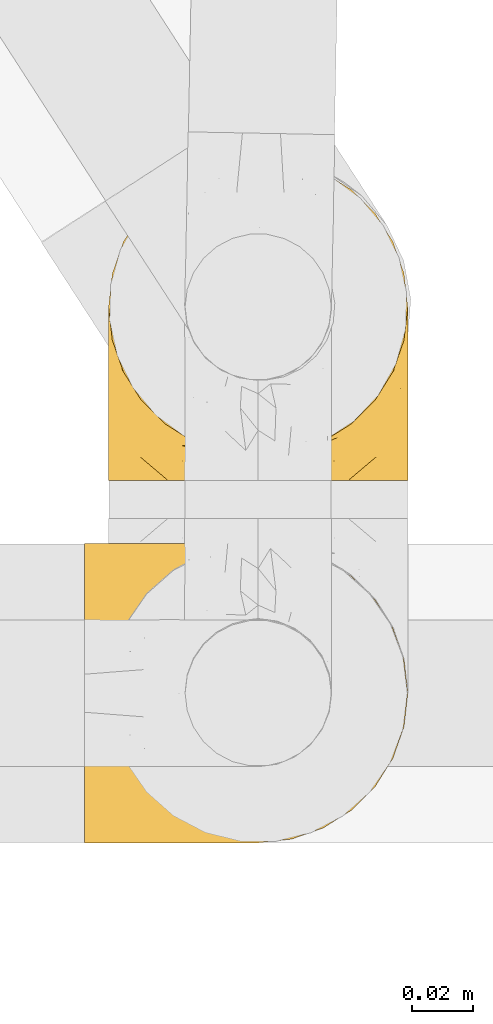
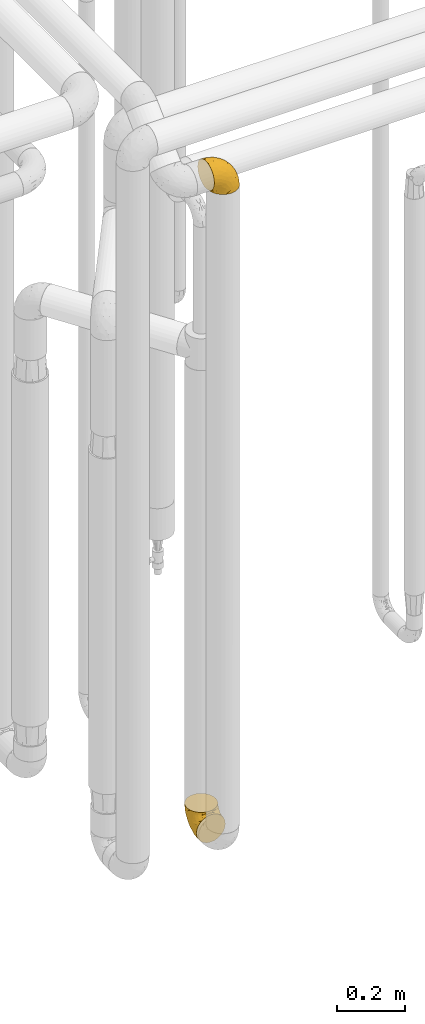
# One storey, part 387 of 827: 2 coverings.
"""IFC2X3 building model written with IfcOpenShell, lengths in millimetres."""

from ifc_helpers import new_model, entity, si_unit, converted_unit, derived_unit, direction, frame, origin, place, context, subcontext, project, spatial, faceted_brep, element, save


model = new_model("IFC2X3")

# Units and contexts
model_context = context("Model", 3, precision=0.01, world=origin(), true_north=direction((6.12303176911189e-17, 1.0)))
body_context = subcontext(model_context, "Body", "Model", "MODEL_VIEW")
ifc_project = project(units=[si_unit("LENGTHUNIT", "METRE", prefix="MILLI"), si_unit("AREAUNIT", "SQUARE_METRE"), si_unit("VOLUMEUNIT", "CUBIC_METRE"), converted_unit("PLANEANGLEUNIT", "DEGREE", entity("IfcRatioMeasure", 0.0174532925199433), si_unit("PLANEANGLEUNIT", "RADIAN"), dimensions=[0, 0, 0, 0, 0, 0, 0]), si_unit("MASSUNIT", "GRAM", prefix="KILO"), derived_unit("MASSDENSITYUNIT", [(si_unit("MASSUNIT", "GRAM", prefix="KILO"), 1), (si_unit("LENGTHUNIT", "METRE"), -3)]), derived_unit("MOMENTOFINERTIAUNIT", [(si_unit("LENGTHUNIT", "METRE"), 4)]), si_unit("TIMEUNIT", "SECOND"), si_unit("FREQUENCYUNIT", "HERTZ"), si_unit("THERMODYNAMICTEMPERATUREUNIT", "DEGREE_CELSIUS"), derived_unit("THERMALTRANSMITTANCEUNIT", [(si_unit("MASSUNIT", "GRAM", prefix="KILO"), 1), (si_unit("THERMODYNAMICTEMPERATUREUNIT", "KELVIN"), -1), (si_unit("TIMEUNIT", "SECOND"), -3)]), derived_unit("VOLUMETRICFLOWRATEUNIT", [(si_unit("LENGTHUNIT", "METRE"), 3), (si_unit("TIMEUNIT", "SECOND"), -1)]), derived_unit("MASSFLOWRATEUNIT", [(si_unit("MASSUNIT", "GRAM", prefix="KILO"), 1), (si_unit("TIMEUNIT", "SECOND"), -1)]), derived_unit("ROTATIONALFREQUENCYUNIT", [(si_unit("TIMEUNIT", "SECOND"), -1)]), si_unit("ELECTRICCURRENTUNIT", "AMPERE"), si_unit("ELECTRICVOLTAGEUNIT", "VOLT"), si_unit("POWERUNIT", "WATT"), si_unit("FORCEUNIT", "NEWTON", prefix="KILO"), si_unit("ILLUMINANCEUNIT", "LUX"), si_unit("LUMINOUSFLUXUNIT", "LUMEN"), si_unit("LUMINOUSINTENSITYUNIT", "CANDELA"), derived_unit("USERDEFINED", [(si_unit("MASSUNIT", "GRAM", prefix="KILO"), -1), (si_unit("LENGTHUNIT", "METRE"), -2), (si_unit("TIMEUNIT", "SECOND"), 3), (si_unit("LUMINOUSFLUXUNIT", "LUMEN"), 1)]), derived_unit("LINEARVELOCITYUNIT", [(si_unit("LENGTHUNIT", "METRE"), 1), (si_unit("TIMEUNIT", "SECOND"), -1)]), si_unit("PRESSUREUNIT", "PASCAL"), derived_unit("USERDEFINED", [(si_unit("LENGTHUNIT", "METRE"), -2), (si_unit("MASSUNIT", "GRAM", prefix="KILO"), 1), (si_unit("TIMEUNIT", "SECOND"), -2)]), derived_unit("LINEARFORCEUNIT", [(si_unit("MASSUNIT", "GRAM", prefix="KILO"), 1), (si_unit("LENGTHUNIT", "METRE"), 1), (si_unit("TIMEUNIT", "SECOND"), -2), (si_unit("LENGTHUNIT", "METRE"), -1)]), derived_unit("PLANARFORCEUNIT", [(si_unit("MASSUNIT", "GRAM", prefix="KILO"), 1), (si_unit("LENGTHUNIT", "METRE"), 1), (si_unit("TIMEUNIT", "SECOND"), -2), (si_unit("LENGTHUNIT", "METRE"), -2)])], contexts=[model_context])

# Site, building, storey
site_placement = place(None, origin())
site = spatial("IfcSite", under=ifc_project, at=site_placement, CompositionType="ELEMENT")
building_placement = place(site_placement, origin())
building = spatial("IfcBuilding", under=site, at=building_placement, CompositionType="ELEMENT")
storey_placement = place(building_placement, frame((0.0, 0.0, 28200.0)))
storey = spatial("IfcBuildingStorey", under=building, at=storey_placement, Name="08", CompositionType="ELEMENT", Elevation=28200.0)

# Coverings
covering_1_placement = place(storey_placement, frame((46939.93, 13586.09, 2751.18)))
element("IfcCovering", 1, at=covering_1_placement, inside=storey, Name=":ADSK_", ObjectType=":ADSK_", PredefinedType="INSULATION", context=body_context, shape_type="Brep", body=[
    faceted_brep([(58.6, 99.9, 1.61), (69.54, 98.67, 1.61), (79.93, 95.03, 1.61), (89.25, 89.18, 1.61), (97.03, 81.39, 1.61), (102.88, 72.07, 1.61), (106.51, 61.69, 1.61), (107.75, 50.75, 1.6), (106.51, 39.81, 1.6), (102.87, 29.42, 1.6), (97.02, 20.1, 1.6), (89.23, 12.32, 1.6), (79.91, 6.47, 1.6), (69.53, 2.84, 1.6), (58.6, 1.6, 1.6), (52.89, 2.25, 1.6), (47.65, 2.84, 1.6), (42.46, 4.66, 1.6), (37.26, 6.48, 1.6), (27.94, 12.33, 1.6), (20.16, 20.12, 1.6), (14.31, 29.44, 1.6), (10.68, 39.82, 1.6), (9.45, 50.75, 1.6), (10.68, 61.7, 1.61), (14.32, 72.09, 1.61), (20.17, 81.41, 1.61), (27.96, 89.19, 1.61), (37.28, 95.04, 1.61), (42.47, 96.86, 1.61), (47.66, 98.67, 1.61), (52.89, 99.26, 1.61), (55.75, 99.58, 1.61), (1.6, 38.03, 11.13), (1.6, 26.18, 16.03), (1.6, 21.09, 19.94), (1.6, 16.0, 23.84), (1.6, 12.09, 28.93), (1.6, 8.18, 34.02), (1.6, 5.73, 39.95), (1.6, 3.27, 45.87), (1.6, 2.35, 52.86), (1.6, 1.97, 55.73), (1.6, 1.6, 58.6), (1.6, 3.27, 71.32), (1.6, 8.18, 83.17), (1.6, 15.99, 93.35), (1.6, 26.16, 101.16), (1.6, 38.02, 106.08), (1.6, 50.74, 107.75), (1.6, 63.46, 106.08), (1.6, 75.31, 101.17), (1.6, 85.49, 93.36), (1.6, 93.31, 83.19), (1.6, 98.22, 71.33), (1.6, 99.9, 58.61), (1.6, 99.14, 52.88), (1.6, 98.22, 45.89), (1.6, 95.77, 39.96), (1.6, 93.31, 34.04), (1.6, 89.41, 28.94), (1.6, 85.51, 23.85), (1.6, 80.42, 19.95), (1.6, 75.33, 16.04), (1.6, 63.47, 11.13), (1.6, 50.75, 9.45), (69.96, 59.3, 81.82), (59.59, 73.07, 84.04), (51.96, 63.71, 93.06), (34.4, 50.74, 102.56), (23.37, 58.63, 104.84), (13.68, 50.74, 105.84), (41.52, 76.73, 91.89), (26.26, 67.68, 101.75), (20.18, 78.92, 97.09), (72.33, 94.31, 38.46), (65.88, 98.77, 22.19), (57.55, 98.4, 42.06), (23.76, 94.56, 77.7), (46.5, 89.91, 75.77), (46.57, 96.32, 62.12), (21.17, 98.78, 66.09), (23.41, 99.9, 54.27), (17.92, 99.9, 55.36), (12.43, 99.9, 56.46), (9.72, 99.9, 56.99), (7.01, 99.9, 57.53), (26.77, 87.31, 87.85), (76.59, 95.61, 19.42), (95.55, 60.43, 48.9), (102.57, 65.24, 26.35), (92.89, 72.87, 44.56), (54.26, 99.9, 23.42), (51.17, 99.9, 28.05), (48.08, 99.9, 32.67), (44.99, 99.9, 37.29), (41.9, 99.9, 41.92), (85.16, 90.65, 20.62), (85.97, 63.14, 63.37), (59.58, 91.89, 62.22), (99.5, 75.26, 19.95), (105.83, 50.75, 13.69), (53.59, 82.18, 80.86), (67.0, 85.08, 66.54), (71.56, 76.93, 71.07), (87.47, 50.74, 64.0), (75.73, 50.74, 75.74), (92.24, 83.02, 26.78), (58.06, 99.9, 4.32), (57.52, 99.9, 7.03), (56.44, 99.9, 12.45), (55.35, 99.9, 17.94), (81.33, 87.14, 43.44), (80.35, 80.85, 56.24), (39.44, 99.17, 54.99), (102.55, 50.75, 34.41), (37.28, 99.9, 45.01), (32.65, 99.9, 48.09), (28.03, 99.9, 51.18), (63.99, 50.74, 87.48), (74.55, 67.6, 74.56), (83.62, 72.25, 60.87), (95.01, 50.75, 49.2), (49.19, 50.74, 95.02), (46.96, 98.7, 10.28), (8.77, 99.02, 48.8), (18.28, 98.8, 45.18), (11.68, 98.29, 45.0), (11.79, 68.52, 6.18), (15.69, 76.83, 7.66), (42.49, 98.54, 21.61), (47.41, 99.3, 19.98), (7.94, 83.58, 21.01), (9.27, 89.47, 27.22), (7.98, 75.77, 14.84), (13.4, 84.86, 19.72), (13.04, 75.89, 10.94), (7.36, 64.78, 9.64), (23.46, 90.84, 19.99), (30.46, 94.63, 21.14), (26.54, 90.38, 14.15), (6.76, 91.19, 30.21), (26.46, 88.65, 8.13), (20.77, 84.12, 9.94), (20.68, 91.75, 24.63), (40.26, 96.87, 11.88), (7.15, 50.75, 7.15), (9.28, 58.98, 5.33), (38.78, 98.38, 26.7), (18.27, 83.92, 13.93), (31.78, 97.53, 30.69), (12.75, 95.55, 36.67), (22.96, 98.76, 42.9), (17.55, 95.26, 34.06), (27.63, 98.04, 36.61), (15.23, 90.66, 26.42), (33.25, 93.52, 10.09), (32.43, 94.17, 15.85), (27.9, 99.1, 42.01), (7.97, 25.74, 14.83), (15.22, 10.85, 26.41), (7.93, 17.92, 21.01), (13.38, 16.65, 19.71), (13.12, 30.45, 5.73), (42.49, 2.96, 21.6), (47.4, 2.2, 19.96), (51.17, 1.6, 28.03), (40.24, 4.64, 11.87), (20.76, 17.4, 9.93), (4.31, 1.6, 58.06), (12.43, 1.6, 56.44), (7.01, 1.6, 57.52), (26.44, 12.87, 8.13), (26.52, 11.13, 14.15), (11.68, 3.2, 44.99), (12.75, 5.95, 36.66), (9.27, 12.02, 27.21), (17.55, 6.24, 34.04), (6.76, 10.31, 30.2), (33.21, 8.01, 10.06), (32.41, 7.34, 15.83), (8.77, 2.48, 48.79), (22.96, 2.73, 42.89), (18.48, 2.64, 45.38), (56.44, 1.6, 12.43), (46.95, 2.81, 10.28), (7.36, 36.72, 9.65), (17.92, 1.6, 55.35), (23.41, 1.6, 54.26), (9.85, 38.59, 6.05), (57.52, 1.6, 7.01), (56.98, 1.6, 9.72), (48.08, 1.6, 32.65), (38.78, 3.12, 26.68), (18.25, 17.59, 13.92), (44.99, 1.6, 37.28), (31.74, 3.99, 30.66), (30.45, 6.87, 21.14), (27.63, 3.46, 36.59), (20.65, 9.77, 24.6), (55.35, 1.6, 17.92), (54.26, 1.6, 23.41), (13.03, 25.63, 10.93), (23.44, 10.67, 19.98), (27.9, 2.39, 41.99), (32.65, 1.6, 48.08), (28.03, 1.6, 51.17), (37.28, 1.6, 44.99), (41.9, 1.6, 41.9), (39.74, 2.4, 55.26), (23.37, 42.84, 104.84), (26.77, 14.17, 87.84), (46.18, 11.55, 75.91), (53.54, 19.27, 80.85), (41.53, 24.75, 91.88), (59.61, 28.37, 83.98), (76.79, 5.95, 19.17), (66.11, 2.8, 22.37), (21.17, 2.7, 66.08), (51.96, 37.77, 93.06), (26.26, 33.8, 101.75), (20.18, 22.56, 97.08), (23.76, 6.92, 77.69), (92.88, 28.61, 44.55), (102.57, 36.24, 26.35), (95.54, 41.05, 48.91), (71.63, 24.55, 70.99), (74.55, 33.88, 74.55), (72.51, 7.12, 37.8), (69.96, 42.18, 81.82), (92.23, 18.47, 26.77), (85.15, 10.84, 20.6), (80.45, 20.69, 56.15), (83.65, 29.27, 60.86), (57.57, 3.1, 42.06), (63.68, 9.18, 57.03), (85.95, 38.38, 63.4), (99.49, 26.23, 19.95), (81.23, 14.35, 43.59), (47.07, 5.46, 62.61), (66.99, 16.39, 66.52)], [[[0, 1, 2, 3, 4, 5, 6, 7, 8, 9, 10, 11, 12, 13, 14, 15, 16, 17, 18, 19, 20, 21, 22, 23, 24, 25, 26, 27, 28, 29, 30, 31, 32]], [[33, 34, 35, 36, 37, 38, 39, 40, 41, 42, 43, 44, 45, 46, 47, 48, 49, 50, 51, 52, 53, 54, 55, 56, 57, 58, 59, 60, 61, 62, 63, 64, 65]], [[66, 67, 68]], [[69, 70, 71]], [[68, 72, 73]], [[73, 72, 74]], [[75, 76, 77]], [[78, 79, 80]], [[51, 50, 73]], [[81, 82, 83, 84, 85, 86, 55]], [[52, 87, 53]], [[74, 52, 51]], [[2, 1, 88]], [[89, 90, 91]], [[77, 92, 93, 94, 95, 96]], [[55, 54, 81]], [[78, 53, 87]], [[5, 90, 6]], [[88, 76, 75]], [[97, 3, 2]], [[89, 91, 98]], [[99, 80, 79]], [[90, 5, 100]], [[74, 87, 52]], [[100, 5, 4]], [[90, 101, 6]], [[79, 102, 103]], [[102, 67, 104]], [[105, 98, 106]], [[107, 4, 3]], [[76, 0, 108, 109, 110, 111, 92]], [[107, 112, 113]], [[114, 77, 96]], [[89, 115, 90]], [[114, 96, 116, 117, 118, 82]], [[75, 97, 88]], [[119, 66, 68]], [[50, 71, 70]], [[100, 91, 90]], [[99, 77, 80]], [[102, 104, 103]], [[97, 107, 3]], [[80, 81, 78]], [[107, 97, 112]], [[68, 73, 70]], [[66, 98, 120]], [[78, 81, 54]], [[114, 81, 80]], [[53, 78, 54]], [[78, 87, 79]], [[102, 87, 72]], [[79, 103, 99]], [[4, 107, 100]], [[91, 100, 107]], [[88, 97, 2]], [[112, 97, 75]], [[99, 112, 75]], [[103, 104, 113]], [[91, 121, 98]], [[89, 105, 122, 115]], [[101, 90, 115]], [[101, 7, 6]], [[88, 1, 76]], [[0, 76, 1]], [[92, 77, 76]], [[73, 74, 51]], [[87, 74, 72]], [[81, 114, 82]], [[77, 114, 80]], [[87, 102, 79]], [[67, 102, 72]], [[68, 67, 72]], [[67, 120, 104]], [[120, 121, 104]], [[104, 121, 113]], [[121, 120, 98]], [[91, 107, 113]], [[91, 113, 121]], [[103, 113, 112]], [[106, 98, 66]], [[105, 89, 98]], [[106, 66, 119]], [[67, 66, 120]], [[68, 69, 123, 119]], [[50, 49, 71]], [[50, 70, 73]], [[112, 99, 103]], [[77, 99, 75]], [[69, 68, 70]], [[29, 124, 110]], [[84, 83, 125]], [[126, 82, 118]], [[59, 58, 127]], [[25, 128, 129]], [[130, 93, 131]], [[132, 62, 133]], [[134, 135, 136]], [[137, 65, 64]], [[64, 134, 137]], [[138, 139, 140]], [[111, 110, 124, 92]], [[134, 136, 137]], [[134, 64, 63]], [[133, 61, 141]], [[125, 58, 57]], [[142, 143, 140]], [[142, 26, 143]], [[127, 83, 82]], [[28, 124, 29]], [[32, 31, 30, 110, 109, 108, 0]], [[30, 29, 110]], [[135, 144, 138]], [[28, 145, 124]], [[57, 56, 55, 86, 85, 84]], [[146, 147, 23]], [[24, 23, 147]], [[25, 143, 26]], [[95, 94, 148]], [[24, 128, 25]], [[149, 138, 143]], [[124, 145, 131]], [[127, 58, 125]], [[150, 148, 139]], [[127, 126, 151]], [[151, 59, 127]], [[152, 151, 126]], [[153, 154, 155]], [[153, 133, 141]], [[145, 28, 27]], [[142, 156, 27]], [[157, 148, 130]], [[61, 133, 62]], [[134, 132, 135]], [[147, 128, 24]], [[65, 137, 146]], [[146, 137, 147]], [[128, 137, 136]], [[137, 128, 147]], [[128, 136, 129]], [[149, 129, 136]], [[25, 129, 143]], [[158, 152, 117]], [[152, 118, 117]], [[153, 151, 152]], [[158, 116, 154]], [[144, 150, 138]], [[153, 152, 158]], [[133, 153, 155]], [[133, 155, 132]], [[141, 61, 60]], [[135, 132, 155]], [[134, 63, 132]], [[144, 135, 155]], [[135, 138, 149]], [[155, 154, 144]], [[150, 154, 96]], [[154, 150, 144]], [[148, 94, 130]], [[82, 126, 127]], [[118, 152, 126]], [[150, 96, 95]], [[139, 148, 157]], [[150, 95, 148]], [[93, 92, 131]], [[130, 145, 156]], [[130, 94, 93]], [[84, 125, 57]], [[127, 125, 83]], [[140, 139, 157]], [[150, 139, 138]], [[140, 157, 142]], [[138, 140, 143]], [[156, 142, 157]], [[27, 26, 142]], [[130, 156, 157]], [[145, 27, 156]], [[132, 63, 62]], [[124, 131, 92]], [[130, 131, 145]], [[129, 149, 143]], [[135, 149, 136]], [[60, 151, 141]], [[59, 151, 60]], [[141, 151, 153]], [[116, 96, 154]], [[153, 158, 154]], [[158, 117, 116]], [[34, 33, 159]], [[160, 161, 162]], [[22, 21, 163]], [[164, 165, 166]], [[19, 18, 167]], [[168, 21, 20]], [[169, 43, 42, 41, 40, 170, 171]], [[172, 173, 168]], [[174, 38, 175]], [[176, 177, 178]], [[179, 164, 180]], [[40, 181, 170]], [[182, 183, 175]], [[17, 184, 185]], [[65, 146, 186]], [[187, 174, 188]], [[23, 22, 189]], [[174, 39, 38]], [[15, 14, 190, 191, 184, 16]], [[181, 40, 39]], [[192, 193, 164]], [[194, 163, 168]], [[33, 186, 159]], [[180, 173, 172]], [[195, 196, 193]], [[18, 185, 167]], [[173, 180, 197]], [[198, 199, 196]], [[200, 201, 185, 184]], [[184, 17, 16]], [[18, 17, 185]], [[202, 159, 186]], [[194, 168, 203]], [[189, 163, 202]], [[204, 205, 182]], [[187, 181, 174]], [[160, 177, 176]], [[206, 183, 182]], [[206, 182, 205]], [[201, 165, 185]], [[165, 164, 167]], [[172, 179, 180]], [[202, 194, 162]], [[176, 161, 160]], [[65, 186, 33]], [[163, 189, 22]], [[175, 177, 182]], [[174, 183, 188]], [[177, 198, 204]], [[199, 160, 162]], [[198, 207, 204]], [[175, 38, 37]], [[198, 177, 160]], [[178, 177, 175]], [[176, 35, 161]], [[34, 159, 161]], [[162, 161, 159]], [[202, 162, 159]], [[199, 162, 203]], [[196, 199, 203]], [[198, 160, 199]], [[193, 197, 180]], [[208, 198, 196]], [[188, 183, 206]], [[175, 183, 174]], [[193, 192, 195]], [[195, 208, 196]], [[197, 196, 203]], [[180, 164, 193]], [[168, 163, 21]], [[166, 165, 201]], [[166, 192, 164]], [[189, 202, 186]], [[186, 146, 189]], [[23, 189, 146]], [[174, 181, 39]], [[170, 181, 187]], [[196, 197, 193]], [[173, 203, 168]], [[203, 173, 197]], [[172, 168, 20]], [[20, 19, 172]], [[179, 172, 19]], [[19, 167, 179]], [[164, 179, 167]], [[35, 176, 36]], [[35, 34, 161]], [[185, 165, 167]], [[162, 194, 203]], [[163, 194, 202]], [[176, 178, 36]], [[37, 36, 178]], [[175, 37, 178]], [[177, 204, 182]], [[207, 198, 208]], [[207, 205, 204]], [[209, 188, 206, 205, 207, 208]], [[48, 210, 71]], [[211, 212, 213]], [[214, 213, 215]], [[216, 217, 13]], [[218, 43, 169, 171, 170, 187, 188]], [[219, 220, 214]], [[47, 46, 221]], [[210, 48, 220]], [[211, 222, 212]], [[222, 45, 44]], [[221, 220, 47]], [[47, 220, 48]], [[221, 211, 214]], [[223, 224, 225]], [[211, 46, 45]], [[226, 227, 215]], [[43, 218, 44]], [[217, 216, 228]], [[215, 229, 219]], [[14, 13, 217]], [[224, 9, 8]], [[10, 230, 11]], [[11, 231, 12]], [[232, 223, 233]], [[234, 208, 195, 192, 166, 201]], [[235, 234, 228]], [[222, 44, 218]], [[106, 229, 236]], [[224, 237, 9]], [[231, 238, 228]], [[9, 237, 10]], [[115, 224, 101]], [[239, 234, 235]], [[231, 11, 230]], [[223, 230, 237]], [[224, 8, 101]], [[223, 236, 233]], [[225, 115, 122, 105]], [[216, 12, 231]], [[209, 234, 239]], [[210, 219, 69]], [[219, 214, 215]], [[229, 119, 219]], [[209, 218, 188]], [[239, 212, 222]], [[239, 222, 218]], [[45, 222, 211]], [[235, 212, 239]], [[213, 212, 240]], [[223, 237, 224]], [[230, 10, 237]], [[238, 231, 230]], [[216, 231, 228]], [[232, 230, 223]], [[235, 238, 240]], [[115, 225, 224]], [[233, 236, 227]], [[8, 7, 101]], [[234, 209, 208]], [[218, 209, 239]], [[217, 228, 234]], [[13, 12, 216]], [[234, 201, 217]], [[217, 201, 200, 184, 191, 190, 14]], [[211, 221, 46]], [[220, 221, 214]], [[71, 210, 69]], [[71, 49, 48]], [[219, 210, 220]], [[226, 215, 213]], [[211, 213, 214]], [[226, 213, 240]], [[215, 227, 229]], [[232, 240, 238]], [[233, 227, 226]], [[232, 233, 226]], [[236, 223, 225]], [[240, 232, 226]], [[232, 238, 230]], [[225, 105, 236]], [[236, 105, 106]], [[229, 106, 119]], [[69, 219, 119, 123]], [[236, 229, 227]], [[238, 235, 228]], [[212, 235, 240]]]),
])
covering_2_placement = place(storey_placement, frame((46947.78, 13705.17, 349.25)))
element("IfcCovering", 2, at=covering_2_placement, inside=storey, Name=":ADSK_", ObjectType=":ADSK_", PredefinedType="INSULATION", context=body_context, shape_type="Brep", body=[
    faceted_brep([(99.9, 58.6, 107.75), (98.66, 69.54, 107.75), (95.02, 79.93, 107.75), (89.17, 89.25, 107.75), (81.38, 97.03, 107.75), (72.06, 102.88, 107.75), (61.68, 106.51, 107.75), (50.75, 107.75, 107.75), (39.8, 106.51, 107.75), (29.41, 102.87, 107.75), (20.09, 97.02, 107.75), (12.31, 89.23, 107.75), (6.46, 79.91, 107.75), (2.83, 69.53, 107.75), (1.6, 58.6, 107.75), (2.24, 52.89, 107.75), (2.83, 47.65, 107.75), (4.65, 42.46, 107.75), (6.47, 37.26, 107.75), (12.32, 27.94, 107.75), (20.11, 20.16, 107.75), (29.43, 14.31, 107.75), (39.81, 10.68, 107.75), (50.75, 9.45, 107.75), (61.69, 10.68, 107.75), (72.08, 14.32, 107.75), (81.4, 20.17, 107.75), (89.18, 27.96, 107.75), (95.03, 37.28, 107.75), (96.85, 42.47, 107.75), (98.66, 47.66, 107.75), (99.25, 52.89, 107.75), (99.57, 55.75, 107.75), (38.02, 1.6, 98.22), (26.17, 1.6, 93.31), (21.08, 1.6, 89.4), (15.99, 1.6, 85.5), (12.09, 1.6, 80.41), (8.18, 1.6, 75.32), (5.73, 1.6, 69.39), (3.27, 1.6, 63.47), (2.35, 1.6, 56.48), (1.97, 1.6, 53.61), (1.6, 1.6, 50.75), (3.27, 1.6, 38.02), (8.18, 1.6, 26.17), (15.99, 1.6, 15.99), (26.17, 1.6, 8.18), (38.02, 1.6, 3.27), (50.75, 1.6, 1.6), (63.47, 1.6, 3.27), (75.32, 1.6, 8.18), (85.5, 1.6, 15.99), (93.31, 1.6, 26.17), (98.22, 1.6, 38.02), (99.9, 1.6, 50.75), (99.14, 1.6, 56.48), (98.22, 1.6, 63.47), (95.77, 1.6, 69.39), (93.31, 1.6, 75.32), (89.4, 1.6, 80.41), (85.5, 1.6, 85.5), (80.41, 1.6, 89.4), (75.32, 1.6, 93.31), (63.47, 1.6, 98.22), (50.75, 1.6, 99.9), (59.31, 69.96, 27.53), (73.08, 59.59, 25.32), (63.72, 51.96, 16.29), (50.75, 34.4, 6.79), (58.64, 23.37, 4.51), (50.75, 13.68, 3.51), (76.74, 41.52, 17.47), (67.68, 26.26, 7.6), (78.92, 20.18, 12.27), (94.31, 72.33, 70.89), (98.76, 65.88, 87.17), (98.4, 57.55, 67.3), (94.57, 23.76, 31.65), (89.91, 46.5, 33.58), (96.32, 46.57, 47.23), (98.79, 21.17, 43.26), (99.9, 23.41, 55.08), (99.9, 17.92, 53.99), (99.9, 12.43, 52.9), (99.9, 9.72, 52.36), (99.9, 7.01, 51.82), (87.31, 26.77, 21.5), (95.61, 76.59, 89.94), (60.43, 95.55, 60.45), (65.24, 102.57, 83.0), (72.87, 92.89, 64.79), (99.9, 54.26, 85.93), (99.9, 51.17, 81.31), (99.9, 48.08, 76.69), (99.9, 44.99, 72.06), (99.9, 41.9, 67.44), (90.65, 85.16, 88.74), (63.14, 85.97, 45.98), (91.89, 59.58, 47.13), (75.25, 99.5, 89.4), (50.75, 105.83, 95.66), (82.18, 53.59, 28.5), (85.08, 67.0, 42.81), (76.93, 71.56, 38.28), (50.75, 87.47, 45.35), (50.75, 75.73, 33.61), (83.02, 92.24, 82.57), (99.9, 58.06, 105.04), (99.9, 57.52, 102.33), (99.9, 56.44, 96.91), (99.9, 55.35, 91.42), (87.13, 81.33, 65.92), (80.85, 80.35, 53.11), (99.17, 39.44, 54.37), (50.75, 102.55, 74.94), (99.9, 37.28, 64.35), (99.9, 32.65, 61.26), (99.9, 28.03, 58.17), (50.75, 63.99, 21.87), (67.61, 74.55, 34.79), (72.25, 83.62, 48.48), (50.75, 95.01, 60.15), (50.75, 49.19, 14.33), (98.69, 46.96, 99.07), (99.01, 8.77, 60.55), (98.79, 18.28, 64.18), (98.29, 11.68, 64.36), (68.51, 11.79, 103.17), (76.82, 15.69, 101.69), (98.54, 42.49, 87.75), (99.3, 47.41, 89.38), (83.57, 7.94, 88.34), (89.47, 9.27, 82.14), (75.76, 7.98, 94.51), (84.86, 13.4, 89.64), (75.89, 13.04, 98.41), (64.77, 7.36, 99.71), (90.83, 23.46, 89.37), (94.62, 30.46, 88.21), (90.37, 26.54, 95.2), (91.18, 6.76, 79.14), (88.65, 26.46, 101.22), (84.11, 20.77, 99.41), (91.75, 20.68, 84.72), (96.86, 40.26, 97.47), (50.75, 7.15, 102.19), (58.97, 9.28, 104.02), (98.37, 38.78, 82.66), (83.91, 18.27, 95.42), (97.52, 31.78, 78.67), (95.55, 12.75, 72.69), (98.76, 22.96, 66.46), (95.26, 17.55, 75.3), (98.04, 27.63, 72.74), (90.65, 15.23, 82.93), (93.51, 33.25, 99.27), (94.16, 32.43, 93.51), (99.1, 27.9, 67.35), (25.73, 7.97, 94.51), (10.84, 15.22, 82.94), (17.92, 7.93, 88.33), (16.64, 13.38, 89.64), (30.44, 13.12, 103.62), (2.95, 42.49, 87.74), (2.19, 47.4, 89.38), (1.6, 51.17, 81.31), (4.63, 40.24, 97.47), (17.39, 20.76, 99.41), (1.6, 12.43, 52.9), (1.6, 7.01, 51.82), (1.6, 4.31, 51.28), (12.86, 26.44, 101.21), (11.13, 26.52, 95.19), (3.2, 11.68, 64.36), (5.94, 12.75, 72.69), (12.02, 9.27, 82.13), (6.23, 17.55, 75.3), (10.31, 6.76, 79.14), (8.0, 33.21, 99.28), (7.34, 32.41, 93.51), (2.48, 8.77, 60.55), (2.73, 22.96, 66.46), (2.64, 18.48, 63.96), (1.6, 56.44, 96.91), (2.8, 46.95, 99.06), (36.71, 7.36, 99.7), (1.6, 17.92, 53.99), (1.6, 23.41, 55.08), (38.59, 9.85, 103.3), (1.6, 57.52, 102.33), (1.6, 56.98, 99.62), (1.6, 48.08, 76.69), (3.12, 38.78, 82.66), (17.59, 18.25, 95.42), (1.6, 44.99, 72.06), (3.98, 31.74, 78.68), (6.87, 30.45, 88.2), (3.45, 27.63, 72.75), (9.76, 20.65, 84.74), (1.6, 55.35, 91.42), (1.6, 54.26, 85.93), (25.62, 13.03, 98.41), (10.67, 23.44, 89.37), (2.39, 27.9, 67.35), (1.6, 32.65, 61.26), (1.6, 28.03, 58.17), (1.6, 37.28, 64.35), (1.6, 41.9, 67.44), (2.4, 39.74, 54.08), (42.85, 23.37, 4.51), (14.18, 26.77, 21.5), (11.56, 46.18, 33.43), (19.27, 53.54, 28.5), (24.75, 41.53, 17.47), (28.37, 59.61, 25.36), (5.95, 76.79, 90.18), (2.79, 66.11, 86.97), (2.71, 21.17, 43.26), (37.78, 51.96, 16.29), (33.81, 26.26, 7.6), (22.57, 20.18, 12.27), (6.92, 23.76, 31.65), (28.61, 92.88, 64.79), (36.24, 102.57, 83.0), (41.05, 95.54, 60.44), (24.55, 71.63, 38.35), (33.88, 74.55, 34.8), (7.11, 72.51, 71.54), (42.18, 69.96, 27.53), (18.46, 92.23, 82.57), (10.84, 85.15, 88.74), (20.69, 80.45, 53.19), (29.27, 83.65, 48.49), (3.1, 57.57, 67.28), (9.18, 63.68, 52.32), (38.38, 85.95, 45.94), (26.23, 99.49, 89.4), (14.34, 81.23, 65.75), (5.46, 47.07, 46.73), (16.39, 66.99, 42.82)], [[[0, 1, 2, 3, 4, 5, 6, 7, 8, 9, 10, 11, 12, 13, 14, 15, 16, 17, 18, 19, 20, 21, 22, 23, 24, 25, 26, 27, 28, 29, 30, 31, 32]], [[33, 34, 35, 36, 37, 38, 39, 40, 41, 42, 43, 44, 45, 46, 47, 48, 49, 50, 51, 52, 53, 54, 55, 56, 57, 58, 59, 60, 61, 62, 63, 64, 65]], [[66, 67, 68]], [[69, 70, 71]], [[68, 72, 73]], [[73, 72, 74]], [[75, 76, 77]], [[78, 79, 80]], [[51, 50, 73]], [[81, 82, 83, 84, 85, 86, 55]], [[52, 87, 53]], [[74, 52, 51]], [[2, 1, 88]], [[89, 90, 91]], [[77, 92, 93, 94, 95, 96]], [[55, 54, 81]], [[78, 53, 87]], [[5, 90, 6]], [[88, 76, 75]], [[97, 3, 2]], [[89, 91, 98]], [[99, 80, 79]], [[90, 5, 100]], [[74, 87, 52]], [[100, 5, 4]], [[90, 101, 6]], [[79, 102, 103]], [[102, 67, 104]], [[105, 98, 106]], [[107, 4, 3]], [[76, 0, 108, 109, 110, 111, 92]], [[107, 112, 113]], [[114, 77, 96]], [[89, 115, 90]], [[114, 96, 116, 117, 118, 82]], [[75, 97, 88]], [[119, 66, 68]], [[50, 71, 70]], [[100, 91, 90]], [[99, 77, 80]], [[102, 104, 103]], [[97, 107, 3]], [[80, 81, 78]], [[107, 97, 112]], [[68, 73, 70]], [[66, 98, 120]], [[78, 81, 54]], [[114, 81, 80]], [[53, 78, 54]], [[78, 87, 79]], [[102, 87, 72]], [[79, 103, 99]], [[4, 107, 100]], [[91, 100, 107]], [[88, 97, 2]], [[112, 97, 75]], [[99, 112, 75]], [[103, 104, 113]], [[91, 121, 98]], [[89, 105, 122, 115]], [[101, 90, 115]], [[101, 7, 6]], [[88, 1, 76]], [[0, 76, 1]], [[92, 77, 76]], [[73, 74, 51]], [[87, 74, 72]], [[81, 114, 82]], [[77, 114, 80]], [[87, 102, 79]], [[67, 102, 72]], [[68, 67, 72]], [[67, 120, 104]], [[120, 121, 104]], [[104, 121, 113]], [[121, 120, 98]], [[91, 107, 113]], [[91, 113, 121]], [[103, 113, 112]], [[106, 98, 66]], [[105, 89, 98]], [[106, 66, 119]], [[67, 66, 120]], [[68, 69, 123, 119]], [[50, 49, 71]], [[50, 70, 73]], [[112, 99, 103]], [[77, 99, 75]], [[69, 68, 70]], [[29, 124, 110]], [[84, 83, 125]], [[126, 82, 118]], [[59, 58, 127]], [[25, 128, 129]], [[130, 93, 131]], [[132, 62, 133]], [[134, 135, 136]], [[137, 65, 64]], [[64, 134, 137]], [[138, 139, 140]], [[111, 110, 124, 92]], [[134, 136, 137]], [[134, 64, 63]], [[141, 61, 60]], [[125, 58, 57]], [[142, 143, 140]], [[142, 26, 143]], [[127, 83, 82]], [[28, 124, 29]], [[108, 0, 32, 31, 30, 110, 109]], [[30, 29, 110]], [[135, 144, 138]], [[28, 145, 124]], [[57, 56, 55, 86, 85, 84]], [[146, 147, 23]], [[24, 23, 147]], [[25, 143, 26]], [[95, 94, 148]], [[24, 128, 25]], [[149, 138, 143]], [[124, 145, 131]], [[127, 58, 125]], [[150, 148, 139]], [[127, 126, 151]], [[151, 59, 127]], [[152, 151, 126]], [[153, 154, 155]], [[153, 133, 141]], [[145, 28, 27]], [[142, 156, 27]], [[157, 148, 130]], [[61, 133, 62]], [[134, 132, 135]], [[147, 128, 24]], [[65, 137, 146]], [[146, 137, 147]], [[128, 137, 136]], [[137, 128, 147]], [[128, 136, 129]], [[149, 129, 136]], [[25, 129, 143]], [[158, 152, 117]], [[152, 118, 117]], [[153, 151, 152]], [[158, 116, 154]], [[144, 150, 138]], [[153, 152, 158]], [[133, 153, 155]], [[133, 155, 132]], [[60, 151, 141]], [[135, 132, 155]], [[134, 63, 132]], [[144, 135, 155]], [[135, 138, 149]], [[155, 154, 144]], [[150, 154, 96]], [[154, 150, 144]], [[148, 94, 130]], [[82, 126, 127]], [[118, 152, 126]], [[150, 96, 95]], [[139, 148, 157]], [[150, 95, 148]], [[93, 92, 131]], [[130, 145, 156]], [[130, 94, 93]], [[84, 125, 57]], [[127, 125, 83]], [[140, 139, 157]], [[150, 139, 138]], [[140, 157, 142]], [[138, 140, 143]], [[156, 142, 157]], [[27, 26, 142]], [[130, 156, 157]], [[145, 27, 156]], [[132, 63, 62]], [[124, 131, 92]], [[130, 131, 145]], [[129, 149, 143]], [[135, 149, 136]], [[141, 133, 61]], [[60, 59, 151]], [[141, 151, 153]], [[116, 96, 154]], [[153, 158, 154]], [[158, 117, 116]], [[34, 33, 159]], [[160, 161, 162]], [[22, 21, 163]], [[164, 165, 166]], [[19, 18, 167]], [[168, 21, 20]], [[42, 41, 40, 169, 170, 171, 43]], [[172, 173, 168]], [[174, 38, 175]], [[176, 177, 178]], [[179, 164, 180]], [[40, 181, 169]], [[182, 183, 175]], [[17, 184, 185]], [[65, 146, 186]], [[187, 174, 188]], [[23, 22, 189]], [[174, 39, 38]], [[15, 14, 190, 191, 184, 16]], [[181, 40, 39]], [[192, 193, 164]], [[194, 163, 168]], [[33, 186, 159]], [[180, 173, 172]], [[195, 196, 193]], [[18, 185, 167]], [[173, 180, 197]], [[198, 199, 196]], [[200, 201, 185, 184]], [[184, 17, 16]], [[18, 17, 185]], [[202, 159, 186]], [[194, 168, 203]], [[189, 163, 202]], [[204, 205, 182]], [[187, 181, 174]], [[160, 177, 176]], [[206, 183, 182]], [[206, 182, 205]], [[201, 165, 185]], [[165, 164, 167]], [[172, 179, 180]], [[202, 194, 162]], [[176, 161, 160]], [[65, 186, 33]], [[163, 189, 22]], [[175, 177, 182]], [[174, 183, 188]], [[177, 198, 204]], [[199, 160, 162]], [[198, 207, 204]], [[175, 38, 37]], [[198, 177, 160]], [[178, 177, 175]], [[176, 35, 161]], [[34, 159, 161]], [[162, 161, 159]], [[202, 162, 159]], [[199, 162, 203]], [[196, 199, 203]], [[198, 160, 199]], [[193, 197, 180]], [[208, 198, 196]], [[188, 183, 206]], [[175, 183, 174]], [[193, 192, 195]], [[195, 208, 196]], [[197, 196, 203]], [[180, 164, 193]], [[168, 163, 21]], [[166, 165, 201]], [[166, 192, 164]], [[189, 202, 186]], [[186, 146, 189]], [[23, 189, 146]], [[174, 181, 39]], [[169, 181, 187]], [[196, 197, 193]], [[173, 203, 168]], [[203, 173, 197]], [[172, 168, 20]], [[20, 19, 172]], [[179, 172, 19]], [[19, 167, 179]], [[164, 179, 167]], [[35, 176, 36]], [[35, 34, 161]], [[185, 165, 167]], [[162, 194, 203]], [[163, 194, 202]], [[176, 178, 36]], [[37, 36, 178]], [[175, 37, 178]], [[177, 204, 182]], [[207, 198, 208]], [[207, 205, 204]], [[209, 188, 206, 205, 207, 208]], [[48, 210, 71]], [[211, 212, 213]], [[214, 213, 215]], [[216, 217, 13]], [[218, 43, 171, 170, 169, 187, 188]], [[219, 220, 214]], [[47, 46, 221]], [[210, 48, 220]], [[211, 222, 212]], [[222, 45, 44]], [[221, 220, 47]], [[47, 220, 48]], [[221, 211, 214]], [[223, 224, 225]], [[211, 46, 45]], [[226, 227, 215]], [[43, 218, 44]], [[217, 216, 228]], [[219, 215, 229]], [[14, 13, 217]], [[224, 9, 8]], [[10, 230, 11]], [[11, 231, 12]], [[232, 223, 233]], [[234, 208, 195, 192, 166, 201]], [[235, 234, 228]], [[222, 44, 218]], [[106, 229, 236]], [[224, 237, 9]], [[231, 238, 228]], [[9, 237, 10]], [[115, 224, 101]], [[239, 234, 235]], [[231, 11, 230]], [[223, 230, 237]], [[224, 8, 101]], [[223, 236, 233]], [[225, 115, 122, 105]], [[216, 12, 231]], [[209, 234, 239]], [[210, 219, 69]], [[219, 214, 215]], [[229, 119, 219]], [[209, 218, 188]], [[239, 212, 222]], [[239, 222, 218]], [[45, 222, 211]], [[235, 212, 239]], [[213, 212, 240]], [[223, 237, 224]], [[230, 10, 237]], [[238, 231, 230]], [[216, 231, 228]], [[232, 230, 223]], [[235, 238, 240]], [[115, 225, 224]], [[233, 236, 227]], [[8, 7, 101]], [[234, 209, 208]], [[218, 209, 239]], [[217, 228, 234]], [[13, 12, 216]], [[234, 201, 217]], [[217, 201, 200, 184, 191, 190, 14]], [[211, 221, 46]], [[220, 221, 214]], [[71, 210, 69]], [[71, 49, 48]], [[219, 210, 220]], [[226, 215, 213]], [[211, 213, 214]], [[226, 213, 240]], [[215, 227, 229]], [[232, 240, 238]], [[233, 227, 226]], [[232, 233, 226]], [[236, 223, 225]], [[240, 232, 226]], [[232, 238, 230]], [[225, 105, 236]], [[236, 105, 106]], [[236, 229, 227]], [[123, 69, 219, 119]], [[106, 119, 229]], [[238, 235, 228]], [[212, 235, 240]]]),
])

save(model, "model.ifc")
